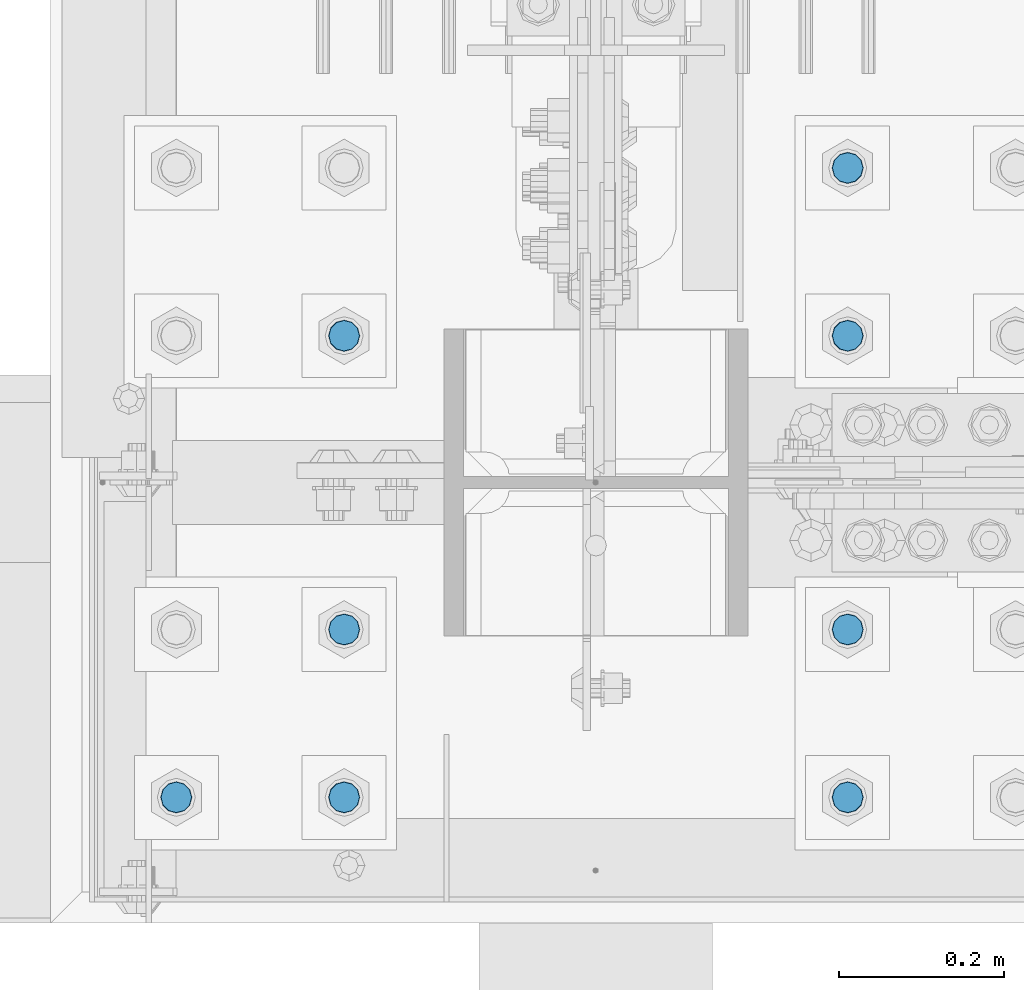
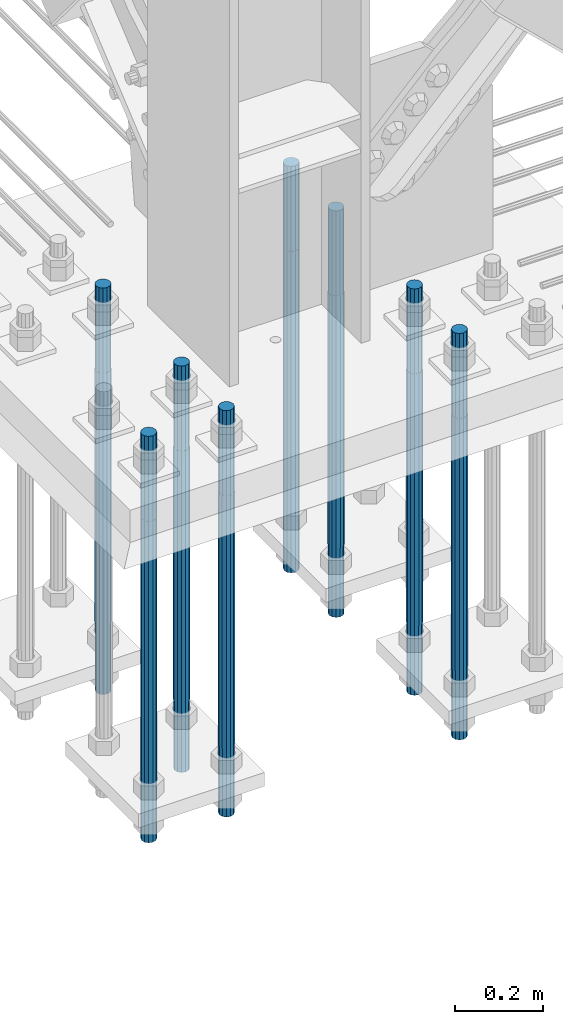
# One storey, part 1288 of 3843: 8 columns, 1 element without a shape of its own.
"""IFC2X3 building model written with IfcOpenShell, lengths in millimetres."""

import ifcopenshell
import ifcopenshell.guid

model = None  # the IFC model being written
_history = None  # IfcOwnerHistory: only IFC2X3 demands one
_inside = {}  # id of a spatial element -> (the spatial element, [elements in it])
_under = {}  # id of a project, library or spatial element -> (it, [spatial elements below it])
_declared = {}  # id of a project -> (the project, [libraries it declares])
_typed = {}  # id of a type object -> (the type object, [elements of that type])
_made_of = {}  # id of a material, layer set ... -> (it, [elements and type objects made of it])


def new_model(schema):
    """Start an empty IFC model of exactly this schema.

    Asked for "IFC4X3", IfcOpenShell would pick the latest addendum, in which some entities
    have other attributes; the version numbers below select the first issue.
    IFC2X3 requires an IfcOwnerHistory on every rooted entity: one is made here for all.
    """
    global model, _history
    if schema == "IFC4X3":
        model = ifcopenshell.file(schema_version=(4, 3, 0, 0))
    else:
        model = ifcopenshell.file(schema=schema)
    _inside.clear()
    _under.clear()
    _declared.clear()
    _typed.clear()
    _made_of.clear()
    _history = None
    if model.schema == "IFC2X3":
        org = make("IfcOrganization", Name="unknown")
        user = make(
            "IfcPersonAndOrganization",
            ThePerson=make("IfcPerson", FamilyName="unknown"),
            TheOrganization=org,
        )
        app = make(
            "IfcApplication",
            ApplicationDeveloper=org,
            Version="unknown",
            ApplicationFullName="unknown",
            ApplicationIdentifier="unknown",
        )
        _history = make(
            "IfcOwnerHistory",
            OwningUser=user,
            OwningApplication=app,
            ChangeAction="ADDED",
            CreationDate=0,
        )
    return model


def make(cls, **values):
    """One entity of the class cls with the attributes given. An attribute that is None is left unset."""
    return model.create_entity(
        cls, **{name: value for name, value in values.items() if value is not None}
    )


def rooted(cls, **values):
    """An entity with a GlobalId (a new one), such as an element, a storey or a relation."""
    return make(cls, GlobalId=ifcopenshell.guid.new(), OwnerHistory=_history, **values)


def si_unit(unit_type, name, prefix=None):
    """IfcSIUnit, for example si_unit("LENGTHUNIT", "METRE", prefix="MILLI")."""
    return make("IfcSIUnit", UnitType=unit_type, Prefix=prefix, Name=name)


def assignment(units):
    """IfcUnitAssignment: the units of a project."""
    return None if units is None else make("IfcUnitAssignment", Units=units)


def point(xyz):
    """IfcCartesianPoint."""
    return None if xyz is None else make("IfcCartesianPoint", Coordinates=xyz)


def direction(xyz):
    """IfcDirection."""
    return None if xyz is None else make("IfcDirection", DirectionRatios=xyz)


def frame(location, z_axis=None, x_axis=None):
    """IfcAxis2Placement3D, a coordinate frame: its origin and axes. An axis left out is left unset."""
    return make(
        "IfcAxis2Placement3D",
        Location=point(location),
        Axis=direction(z_axis),
        RefDirection=direction(x_axis),
    )


def origin_with_axes():
    """The frame at (0, 0, 0) with the z axis (0, 0, 1) and the x axis (1, 0, 0) written out."""
    return frame((0.0, 0.0, 0.0), z_axis=(0.0, 0.0, 1.0), x_axis=(1.0, 0.0, 0.0))


def place(relative_to, where):
    """IfcLocalPlacement: puts the frame where relative to a parent placement (None: the world)."""
    return make(
        "IfcLocalPlacement", PlacementRelTo=relative_to, RelativePlacement=where
    )


def context(
    kind, dimensions, precision=None, world=None, true_north=None, identifier=None
):
    """IfcGeometricRepresentationContext, for example the 3D "Model" context."""
    return make(
        "IfcGeometricRepresentationContext",
        ContextIdentifier=identifier,
        ContextType=kind,
        CoordinateSpaceDimension=dimensions,
        Precision=precision,
        WorldCoordinateSystem=world,
        TrueNorth=true_north,
    )


def subcontext(parent, identifier, kind, view, scale=None):
    """IfcGeometricRepresentationSubContext, for example "Body" below "Model"."""
    return make(
        "IfcGeometricRepresentationSubContext",
        ContextIdentifier=identifier,
        ContextType=kind,
        ParentContext=parent,
        TargetScale=scale,
        TargetView=view,
    )


def project(units=None, contexts=None):
    """IfcProject with its units and contexts."""
    return rooted(
        "IfcProject",
        Name="project",
        RepresentationContexts=contexts,
        UnitsInContext=assignment(units),
    )


def spatial(cls, under=None, at=None, **own):
    """A site, building, storey or space (cls), placed at a placement, below another one or the project."""
    s = rooted(cls, ObjectPlacement=at, **own)
    if under is not None:
        _under.setdefault(under.id(), (under, []))[1].append(s)
    return s


def faces_of(points, faces, orient=None, outer=None):
    """IfcFace entities. A face is a list of loops; a loop is a list of indices into points, from 0.

    orient and outer hold one flag for each loop. By default every Orientation is true, the
    first loop of a face is its IfcFaceOuterBound and the others are IfcFaceBound.
    """
    made = []
    for i, loops in enumerate(faces):
        bounds = []
        for j, loop in enumerate(loops):
            is_outer = j == 0 if outer is None else outer[i][j]
            bounds.append(
                make(
                    "IfcFaceOuterBound" if is_outer else "IfcFaceBound",
                    Bound=make("IfcPolyLoop", Polygon=[points[k] for k in loop]),
                    Orientation=True if orient is None else orient[i][j],
                )
            )
        made.append(make("IfcFace", Bounds=bounds))
    return made


def faceted_brep(points, faces, orient=None, outer=None, voids=None):
    """IfcFacetedBrep: a solid bounded by flat faces; with voids (closed shells), ...WithVoids."""
    shared = [point(p) for p in points]
    hull = make("IfcClosedShell", CfsFaces=faces_of(shared, faces, orient, outer))
    if voids is None:
        return make("IfcFacetedBrep", Outer=hull)
    return make(
        "IfcFacetedBrepWithVoids",
        Outer=hull,
        Voids=[
            make(cls, CfsFaces=faces_of(shared, fs, o, b)) for cls, fs, o, b in voids
        ],
    )


def shape(context_of_items, identifier, shape_type, items):
    """IfcShapeRepresentation: the items that make up one representation, for example the "Body"."""
    return make(
        "IfcShapeRepresentation",
        ContextOfItems=context_of_items,
        RepresentationIdentifier=identifier,
        RepresentationType=shape_type,
        Items=items,
    )


def material(Name=None, Category=None):
    """IfcMaterial."""
    return make("IfcMaterial", Name=Name, Category=Category)


def made_of(thing, what):
    """Note that an element or type object is made of a material, layer set ...; save() writes the relation."""
    if what is not None:
        _made_of.setdefault(what.id(), (what, []))[1].append(thing)
    return thing


def type_object(cls, material=None, **own):
    """A type object (cls), such as IfcWallType, which elements share."""
    return made_of(rooted(cls, **own), material)


def element(
    cls,
    number,
    at=None,
    inside=None,
    cuts=None,
    type_object=None,
    material=None,
    context=None,
    identifier="Body",
    shape_type=None,
    held_by="IfcProductDefinitionShape",
    body=None,
    shapes=None,
    **own,
):
    """One element of the class cls, such as IfcWall. Its Tag is "e" and its number.

    at: its placement. inside: the storey or other place that contains it. cuts: it is an
    opening in that element (IfcRelVoidsElement). A single representation is given by context,
    identifier, shape_type and body (its items); several are given by shapes. held_by: the class
    of the entity that holds the representations. save() writes the other relations.
    """
    e = rooted(cls, Tag="e%d" % number, ObjectPlacement=at, **own)
    if body is not None:
        shapes = [shape(context, identifier, shape_type, body)]
    if shapes is not None:
        e.Representation = make(held_by, Representations=shapes)
    if inside is not None:
        _inside.setdefault(inside.id(), (inside, []))[1].append(e)
    if cuts is not None:
        rooted(
            "IfcRelVoidsElement", RelatingBuildingElement=cuts, RelatedOpeningElement=e
        )
    if type_object is not None:
        _typed.setdefault(type_object.id(), (type_object, []))[1].append(e)
    return made_of(e, material)


def aggregate(whole, parts):
    """IfcRelAggregates: a whole, such as a stair, and the parts it consists of."""
    return rooted("IfcRelAggregates", RelatingObject=whole, RelatedObjects=parts)


def save(model, path):
    """Write the relations noted so far, then the file.

    IfcRelAggregates (storeys below a building ...), IfcRelContainedInSpatialStructure (elements
    in a storey), IfcRelDefinesByType, IfcRelAssociatesMaterial and IfcRelDeclares: one each for
    every whole, place, type object, material and project.
    """
    for whole, parts in _under.values():
        aggregate(whole, parts)
    for where, things in _inside.values():
        rooted(
            "IfcRelContainedInSpatialStructure",
            RelatedElements=things,
            RelatingStructure=where,
        )
    for kind, things in _typed.values():
        rooted("IfcRelDefinesByType", RelatedObjects=things, RelatingType=kind)
    for what, things in _made_of.values():
        rooted("IfcRelAssociatesMaterial", RelatedObjects=things, RelatingMaterial=what)
    for by, libraries in _declared.values():
        rooted("IfcRelDeclares", RelatingContext=by, RelatedDefinitions=libraries)
    model.write(path)


model = new_model("IFC2X3")

# Units and contexts
model_context = context("Model", 3, precision=1e-05, world=origin_with_axes())
body_context = subcontext(model_context, "Body", "Model", "MODEL_VIEW")
ifc_project = project(units=[si_unit("LENGTHUNIT", "METRE", prefix="MILLI"), si_unit("AREAUNIT", "SQUARE_METRE"), si_unit("VOLUMEUNIT", "CUBIC_METRE"), si_unit("MASSUNIT", "GRAM", prefix="KILO"), si_unit("TIMEUNIT", "SECOND"), si_unit("PLANEANGLEUNIT", "RADIAN"), si_unit("SOLIDANGLEUNIT", "STERADIAN"), si_unit("THERMODYNAMICTEMPERATUREUNIT", "DEGREE_CELSIUS"), si_unit("LUMINOUSINTENSITYUNIT", "LUMEN")], contexts=[model_context])

# Site, building, storey
site_placement = place(None, origin_with_axes())
site = spatial("IfcSite", under=ifc_project, at=site_placement, CompositionType="ELEMENT")
building_placement = place(site_placement, origin_with_axes())
building = spatial("IfcBuilding", under=site, at=building_placement, Name="Undefined", CompositionType="ELEMENT")
storey_placement = place(building_placement, origin_with_axes())
storey = spatial("IfcBuildingStorey", under=building, at=storey_placement, Name="Undefined", CompositionType="ELEMENT", Elevation=0.0)

# Assembly, columns
assembly_placement = place(storey_placement, origin_with_axes())
assembly = element("IfcElementAssembly", 1, at=assembly_placement, inside=storey, Name="TEMPLATE", AssemblyPlace="NOTDEFINED", PredefinedType="RIGID_FRAME")
ifc_material = material(Name="Undefined/F1554-GR.55")
column_type = type_object("IfcColumnType", PredefinedType="NOTDEFINED")
column_1_placement = place(assembly_placement, frame((77317.6, 14617.7, 30022.8), z_axis=(1.0, 0.0, 0.0), x_axis=(0.0, 0.0, -1.0)))
column_1 = element("IfcColumn", 2, at=column_1_placement, type_object=column_type, material=ifc_material, Name="ANCHOR_ROD", context=body_context, shape_type="Brep", body=[
    faceted_brep([(-234.950000000001, -16.0214699700155, 9.25), (-234.950000000001, -9.25, 16.0214699700155), (-234.950000000001, 0.0, 18.5), (-234.950000000001, 9.25, 16.0214699700155), (-234.950000000001, 16.0214699700155, 9.25), (-234.950000000001, 18.5, 0.0), (-234.950000000001, 16.0214699700155, -9.25), (-234.950000000001, 9.25, -16.0214699700155), (-234.950000000001, 0.0, -18.5), (-234.950000000001, -9.25, -16.0214699700155), (-234.950000000001, -16.0214699700155, -9.25), (-234.950000000001, -18.5, 0.0), (0.0, 18.5, 0.0), (0.0, 16.0214699700118, -9.25), (0.0, 9.25, -16.0214699700155), (0.0, 0.0, -18.5), (0.0, -9.25, -16.0214699700155), (0.0, -16.0214699700118, -9.25), (0.0, -18.5, 0.0), (0.0, -16.0214699700118, 9.25), (0.0, -9.25, 16.0214699700155), (0.0, 0.0, 18.5), (0.0, 9.25, 16.0214699700155), (0.0, 16.0214699700118, 9.25), (0.0, -16.4977839420972, 9.52500000000146), (0.0, -9.52500000000146, 16.4977839420972), (0.0, 0.0, 19.0499989999989), (0.0, 9.52500000000146, 16.4977839420972), (0.0, 16.4977839420972, 9.52500000000146), (0.0, 19.0500000000029, 0.0), (0.0, 16.4977839420972, -9.52500000000146), (0.0, 9.52500000000146, -16.4977839420972), (0.0, 0.0, -19.0499989999989), (0.0, -9.52500000000146, -16.4977839420972), (0.0, -16.4977839420972, -9.52500000000146), (0.0, -19.0500000000029, 0.0), (698.5, -19.0499999999993, 0.0), (698.5, -16.4977839420935, 9.52499999999418), (698.5, -9.52500000000146, 16.4977839420899), (698.5, 0.0, 19.0500000000029), (698.5, 9.52500000000146, 16.4977839420899), (698.5, 16.4977839420935, 9.52499999999418), (698.5, 19.0499999999993, 0.0), (698.5, 16.4977839420935, -9.52499999999418), (698.5, 9.52500000000146, -16.4977839420899), (698.5, 0.0, -19.0500000000029), (698.5, -9.52500000000146, -16.4977839420899), (698.5, -16.4977839420935, -9.52499999999418), (698.5, -9.25, 16.0214699700155), (698.5, 0.0, 18.5), (698.5, 9.25, 16.0214699700155), (698.5, 16.0214699700118, 9.25), (698.5, 18.5, 0.0), (698.5, 16.0214699700118, -9.25), (698.5, 9.25, -16.0214699700155), (698.5, 0.0, -18.5), (698.5, -9.25, -16.0214699700155), (698.5, -16.0214699700118, -9.25), (698.5, -18.5, 0.0), (698.5, -16.0214699700118, 9.25), (889.0, -9.25, -16.0214699700155), (889.0, 0.0, -18.5), (889.0, 9.25, -16.0214699700155), (889.0, 16.0214699700118, -9.25), (889.0, 18.5, 0.0), (889.0, 16.0214699700118, 9.25), (889.0, 9.25, 16.0214699700155), (889.0, 0.0, 18.5), (889.0, -9.25, 16.0214699700155), (889.0, -16.0214699700118, 9.25), (889.0, -18.5, 0.0), (889.0, -16.0214699700118, -9.25)], [[[0, 1, 2, 3, 4, 5, 6, 7, 8, 9, 10, 11]], [[6, 5, 12, 13]], [[7, 6, 13, 14]], [[8, 7, 14, 15]], [[9, 8, 15, 16]], [[10, 9, 16, 17]], [[11, 10, 17, 18]], [[0, 11, 18, 19]], [[1, 0, 19, 20]], [[2, 1, 20, 21]], [[3, 2, 21, 22]], [[4, 3, 22, 23]], [[5, 4, 23, 12]], [[24, 25, 26, 27, 28, 29, 30, 31, 32, 33, 34, 35], [22, 21, 20, 19, 18, 17, 16, 15, 14, 13, 12, 23]], [[24, 35, 36, 37]], [[25, 24, 37, 38]], [[26, 25, 38, 39]], [[27, 26, 39, 40]], [[28, 27, 40, 41]], [[29, 28, 41, 42]], [[30, 29, 42, 43]], [[31, 30, 43, 44]], [[32, 31, 44, 45]], [[33, 32, 45, 46]], [[34, 33, 46, 47]], [[35, 34, 47, 36]], [[46, 45, 44, 43, 42, 41, 40, 39, 38, 37, 36, 47], [48, 49, 50, 51, 52, 53, 54, 55, 56, 57, 58, 59]], [[60, 61, 62, 63, 64, 65, 66, 67, 68, 69, 70, 71]], [[68, 67, 49, 48]], [[69, 68, 48, 59]], [[70, 69, 59, 58]], [[71, 70, 58, 57]], [[60, 71, 57, 56]], [[61, 60, 56, 55]], [[62, 61, 55, 54]], [[63, 62, 54, 53]], [[64, 63, 53, 52]], [[65, 64, 52, 51]], [[66, 65, 51, 50]], [[67, 66, 50, 49]]]),
])
column_2_placement = place(assembly_placement, frame((77317.6, 14820.9, 30022.8), z_axis=(1.0, 0.0, 0.0), x_axis=(0.0, 0.0, -1.0)))
column_2 = element("IfcColumn", 3, at=column_2_placement, type_object=column_type, material=ifc_material, Name="ANCHOR_ROD", context=body_context, shape_type="Brep", body=[
    faceted_brep([(-234.950000000001, -16.0214699700155, 9.25), (-234.950000000001, -9.25, 16.0214699700155), (-234.950000000001, 0.0, 18.5), (-234.950000000001, 9.25, 16.0214699700155), (-234.950000000001, 16.0214699700155, 9.25), (-234.950000000001, 18.5, 0.0), (-234.950000000001, 16.0214699700155, -9.25), (-234.950000000001, 9.25, -16.0214699700155), (-234.950000000001, 0.0, -18.5), (-234.950000000001, -9.25, -16.0214699700155), (-234.950000000001, -16.0214699700155, -9.25), (-234.950000000001, -18.5, 0.0), (0.0, 18.5, 0.0), (0.0, 16.0214699700118, -9.25), (0.0, 9.25, -16.0214699700155), (0.0, 0.0, -18.5), (0.0, -9.25, -16.0214699700155), (0.0, -16.0214699700118, -9.25), (0.0, -18.5, 0.0), (0.0, -16.0214699700118, 9.25), (0.0, -9.25, 16.0214699700155), (0.0, 0.0, 18.5), (0.0, 9.25, 16.0214699700155), (0.0, 16.0214699700118, 9.25), (0.0, -16.4977839420972, 9.52500000000146), (0.0, -9.52500000000146, 16.4977839420972), (0.0, 0.0, 19.0499989999989), (0.0, 9.52500000000146, 16.4977839420972), (0.0, 16.4977839420972, 9.52500000000146), (0.0, 19.0500000000029, 0.0), (0.0, 16.4977839420972, -9.52500000000146), (0.0, 9.52500000000146, -16.4977839420972), (0.0, 0.0, -19.0499989999989), (0.0, -9.52500000000146, -16.4977839420972), (0.0, -16.4977839420972, -9.52500000000146), (0.0, -19.0500000000029, 0.0), (698.5, -19.0499999999993, 0.0), (698.5, -16.4977839420935, 9.52499999999418), (698.5, -9.52500000000146, 16.4977839420899), (698.5, 0.0, 19.0500000000029), (698.5, 9.52500000000146, 16.4977839420899), (698.5, 16.4977839420935, 9.52499999999418), (698.5, 19.0499999999993, 0.0), (698.5, 16.4977839420935, -9.52499999999418), (698.5, 9.52500000000146, -16.4977839420899), (698.5, 0.0, -19.0500000000029), (698.5, -9.52500000000146, -16.4977839420899), (698.5, -16.4977839420935, -9.52499999999418), (698.5, -9.25, 16.0214699700155), (698.5, 0.0, 18.5), (698.5, 9.25, 16.0214699700155), (698.5, 16.0214699700118, 9.25), (698.5, 18.5, 0.0), (698.5, 16.0214699700118, -9.25), (698.5, 9.25, -16.0214699700155), (698.5, 0.0, -18.5), (698.5, -9.25, -16.0214699700155), (698.5, -16.0214699700118, -9.25), (698.5, -18.5, 0.0), (698.5, -16.0214699700118, 9.25), (889.0, -9.25, -16.0214699700155), (889.0, 0.0, -18.5), (889.0, 9.25, -16.0214699700155), (889.0, 16.0214699700118, -9.25), (889.0, 18.5, 0.0), (889.0, 16.0214699700118, 9.25), (889.0, 9.25, 16.0214699700155), (889.0, 0.0, 18.5), (889.0, -9.25, 16.0214699700155), (889.0, -16.0214699700118, 9.25), (889.0, -18.5, 0.0), (889.0, -16.0214699700118, -9.25)], [[[0, 1, 2, 3, 4, 5, 6, 7, 8, 9, 10, 11]], [[6, 5, 12, 13]], [[7, 6, 13, 14]], [[8, 7, 14, 15]], [[9, 8, 15, 16]], [[10, 9, 16, 17]], [[11, 10, 17, 18]], [[0, 11, 18, 19]], [[1, 0, 19, 20]], [[2, 1, 20, 21]], [[3, 2, 21, 22]], [[4, 3, 22, 23]], [[5, 4, 23, 12]], [[24, 25, 26, 27, 28, 29, 30, 31, 32, 33, 34, 35], [22, 21, 20, 19, 18, 17, 16, 15, 14, 13, 12, 23]], [[24, 35, 36, 37]], [[25, 24, 37, 38]], [[26, 25, 38, 39]], [[27, 26, 39, 40]], [[28, 27, 40, 41]], [[29, 28, 41, 42]], [[30, 29, 42, 43]], [[31, 30, 43, 44]], [[32, 31, 44, 45]], [[33, 32, 45, 46]], [[34, 33, 46, 47]], [[35, 34, 47, 36]], [[46, 45, 44, 43, 42, 41, 40, 39, 38, 37, 36, 47], [48, 49, 50, 51, 52, 53, 54, 55, 56, 57, 58, 59]], [[60, 61, 62, 63, 64, 65, 66, 67, 68, 69, 70, 71]], [[68, 67, 49, 48]], [[69, 68, 48, 59]], [[70, 69, 59, 58]], [[71, 70, 58, 57]], [[60, 71, 57, 56]], [[61, 60, 56, 55]], [[62, 61, 55, 54]], [[63, 62, 54, 53]], [[64, 63, 53, 52]], [[65, 64, 52, 51]], [[66, 65, 51, 50]], [[67, 66, 50, 49]]]),
])
column_3_placement = place(assembly_placement, frame((77317.6, 15176.5, 30022.8), z_axis=(-1.0, 0.0, 0.0), x_axis=(0.0, 0.0, -1.0)))
column_3 = element("IfcColumn", 4, at=column_3_placement, type_object=column_type, material=ifc_material, Name="ANCHOR_ROD", context=body_context, shape_type="Brep", body=[
    faceted_brep([(-234.950000000001, -16.0214699700155, 9.25), (-234.950000000001, -9.25, 16.0214699700155), (-234.950000000001, 0.0, 18.5), (-234.950000000001, 9.25, 16.0214699700155), (-234.950000000001, 16.0214699700155, 9.25), (-234.950000000001, 18.5, 0.0), (-234.950000000001, 16.0214699700155, -9.25), (-234.950000000001, 9.25, -16.0214699700155), (-234.950000000001, 0.0, -18.5), (-234.950000000001, -9.25, -16.0214699700155), (-234.950000000001, -16.0214699700155, -9.25), (-234.950000000001, -18.5, 0.0), (0.0, 18.5, 0.0), (0.0, 16.0214699700118, -9.25), (0.0, 9.25, -16.0214699700155), (0.0, 0.0, -18.5), (0.0, -9.25, -16.0214699700155), (0.0, -16.0214699700118, -9.25), (0.0, -18.5, 0.0), (0.0, -16.0214699700118, 9.25), (0.0, -9.25, 16.0214699700155), (0.0, 0.0, 18.5), (0.0, 9.25, 16.0214699700155), (0.0, 16.0214699700118, 9.25), (0.0, -16.4977839420972, 9.52500000000146), (0.0, -9.52500000000146, 16.4977839420972), (0.0, 0.0, 19.0499989999989), (0.0, 9.52500000000146, 16.4977839420972), (0.0, 16.4977839420972, 9.52500000000146), (0.0, 19.0500000000029, 0.0), (0.0, 16.4977839420972, -9.52500000000146), (0.0, 9.52500000000146, -16.4977839420972), (0.0, 0.0, -19.0499989999989), (0.0, -9.52500000000146, -16.4977839420972), (0.0, -16.4977839420972, -9.52500000000146), (0.0, -19.0500000000029, 0.0), (698.5, -19.0499999999993, 0.0), (698.5, -16.4977839420935, 9.52499999999418), (698.5, -9.52500000000146, 16.4977839420899), (698.5, 0.0, 19.0500000000029), (698.5, 9.52500000000146, 16.4977839420899), (698.5, 16.4977839420935, 9.52499999999418), (698.5, 19.0499999999993, 0.0), (698.5, 16.4977839420935, -9.52499999999418), (698.5, 9.52500000000146, -16.4977839420899), (698.5, 0.0, -19.0500000000029), (698.5, -9.52500000000146, -16.4977839420899), (698.5, -16.4977839420935, -9.52499999999418), (698.5, -9.25, 16.0214699700155), (698.5, 0.0, 18.5), (698.5, 9.25, 16.0214699700155), (698.5, 16.0214699700118, 9.25), (698.5, 18.5, 0.0), (698.5, 16.0214699700118, -9.25), (698.5, 9.25, -16.0214699700155), (698.5, 0.0, -18.5), (698.5, -9.25, -16.0214699700155), (698.5, -16.0214699700118, -9.25), (698.5, -18.5, 0.0), (698.5, -16.0214699700118, 9.25), (889.0, -9.25, -16.0214699700155), (889.0, 0.0, -18.5), (889.0, 9.25, -16.0214699700155), (889.0, 16.0214699700118, -9.25), (889.0, 18.5, 0.0), (889.0, 16.0214699700118, 9.25), (889.0, 9.25, 16.0214699700155), (889.0, 0.0, 18.5), (889.0, -9.25, 16.0214699700155), (889.0, -16.0214699700118, 9.25), (889.0, -18.5, 0.0), (889.0, -16.0214699700118, -9.25)], [[[0, 1, 2, 3, 4, 5, 6, 7, 8, 9, 10, 11]], [[6, 5, 12, 13]], [[7, 6, 13, 14]], [[8, 7, 14, 15]], [[9, 8, 15, 16]], [[10, 9, 16, 17]], [[11, 10, 17, 18]], [[0, 11, 18, 19]], [[1, 0, 19, 20]], [[2, 1, 20, 21]], [[3, 2, 21, 22]], [[4, 3, 22, 23]], [[5, 4, 23, 12]], [[24, 25, 26, 27, 28, 29, 30, 31, 32, 33, 34, 35], [22, 21, 20, 19, 18, 17, 16, 15, 14, 13, 12, 23]], [[24, 35, 36, 37]], [[25, 24, 37, 38]], [[26, 25, 38, 39]], [[27, 26, 39, 40]], [[28, 27, 40, 41]], [[29, 28, 41, 42]], [[30, 29, 42, 43]], [[31, 30, 43, 44]], [[32, 31, 44, 45]], [[33, 32, 45, 46]], [[34, 33, 46, 47]], [[35, 34, 47, 36]], [[46, 45, 44, 43, 42, 41, 40, 39, 38, 37, 36, 47], [48, 49, 50, 51, 52, 53, 54, 55, 56, 57, 58, 59]], [[60, 61, 62, 63, 64, 65, 66, 67, 68, 69, 70, 71]], [[68, 67, 49, 48]], [[69, 68, 48, 59]], [[70, 69, 59, 58]], [[71, 70, 58, 57]], [[60, 71, 57, 56]], [[61, 60, 56, 55]], [[62, 61, 55, 54]], [[63, 62, 54, 53]], [[64, 63, 53, 52]], [[65, 64, 52, 51]], [[66, 65, 51, 50]], [[67, 66, 50, 49]]]),
])
column_4_placement = place(assembly_placement, frame((77317.6, 15379.7, 30022.8), z_axis=(-1.0, 0.0, 0.0), x_axis=(0.0, 0.0, -1.0)))
column_4 = element("IfcColumn", 5, at=column_4_placement, type_object=column_type, material=ifc_material, Name="ANCHOR_ROD", context=body_context, shape_type="Brep", body=[
    faceted_brep([(-234.950000000001, -16.0214699700155, 9.25), (-234.950000000001, -9.25, 16.0214699700155), (-234.950000000001, 0.0, 18.5), (-234.950000000001, 9.25, 16.0214699700155), (-234.950000000001, 16.0214699700155, 9.25), (-234.950000000001, 18.5, 0.0), (-234.950000000001, 16.0214699700155, -9.25), (-234.950000000001, 9.25, -16.0214699700155), (-234.950000000001, 0.0, -18.5), (-234.950000000001, -9.25, -16.0214699700155), (-234.950000000001, -16.0214699700155, -9.25), (-234.950000000001, -18.5, 0.0), (0.0, 18.5, 0.0), (0.0, 16.0214699700118, -9.25), (0.0, 9.25, -16.0214699700155), (0.0, 0.0, -18.5), (0.0, -9.25, -16.0214699700155), (0.0, -16.0214699700118, -9.25), (0.0, -18.5, 0.0), (0.0, -16.0214699700118, 9.25), (0.0, -9.25, 16.0214699700155), (0.0, 0.0, 18.5), (0.0, 9.25, 16.0214699700155), (0.0, 16.0214699700118, 9.25), (0.0, -16.4977839420972, 9.52500000000146), (0.0, -9.52500000000146, 16.4977839420972), (0.0, 0.0, 19.0499989999989), (0.0, 9.52500000000146, 16.4977839420972), (0.0, 16.4977839420972, 9.52500000000146), (0.0, 19.0500000000029, 0.0), (0.0, 16.4977839420972, -9.52500000000146), (0.0, 9.52500000000146, -16.4977839420972), (0.0, 0.0, -19.0499989999989), (0.0, -9.52500000000146, -16.4977839420972), (0.0, -16.4977839420972, -9.52500000000146), (0.0, -19.0500000000029, 0.0), (698.5, -19.0499999999993, 0.0), (698.5, -16.4977839420935, 9.52499999999418), (698.5, -9.52500000000146, 16.4977839420899), (698.5, 0.0, 19.0500000000029), (698.5, 9.52500000000146, 16.4977839420899), (698.5, 16.4977839420935, 9.52499999999418), (698.5, 19.0499999999993, 0.0), (698.5, 16.4977839420935, -9.52499999999418), (698.5, 9.52500000000146, -16.4977839420899), (698.5, 0.0, -19.0500000000029), (698.5, -9.52500000000146, -16.4977839420899), (698.5, -16.4977839420935, -9.52499999999418), (698.5, -9.25, 16.0214699700155), (698.5, 0.0, 18.5), (698.5, 9.25, 16.0214699700155), (698.5, 16.0214699700118, 9.25), (698.5, 18.5, 0.0), (698.5, 16.0214699700118, -9.25), (698.5, 9.25, -16.0214699700155), (698.5, 0.0, -18.5), (698.5, -9.25, -16.0214699700155), (698.5, -16.0214699700118, -9.25), (698.5, -18.5, 0.0), (698.5, -16.0214699700118, 9.25), (889.0, -9.25, -16.0214699700155), (889.0, 0.0, -18.5), (889.0, 9.25, -16.0214699700155), (889.0, 16.0214699700118, -9.25), (889.0, 18.5, 0.0), (889.0, 16.0214699700118, 9.25), (889.0, 9.25, 16.0214699700155), (889.0, 0.0, 18.5), (889.0, -9.25, 16.0214699700155), (889.0, -16.0214699700118, 9.25), (889.0, -18.5, 0.0), (889.0, -16.0214699700118, -9.25)], [[[0, 1, 2, 3, 4, 5, 6, 7, 8, 9, 10, 11]], [[6, 5, 12, 13]], [[7, 6, 13, 14]], [[8, 7, 14, 15]], [[9, 8, 15, 16]], [[10, 9, 16, 17]], [[11, 10, 17, 18]], [[0, 11, 18, 19]], [[1, 0, 19, 20]], [[2, 1, 20, 21]], [[3, 2, 21, 22]], [[4, 3, 22, 23]], [[5, 4, 23, 12]], [[24, 25, 26, 27, 28, 29, 30, 31, 32, 33, 34, 35], [22, 21, 20, 19, 18, 17, 16, 15, 14, 13, 12, 23]], [[24, 35, 36, 37]], [[25, 24, 37, 38]], [[26, 25, 38, 39]], [[27, 26, 39, 40]], [[28, 27, 40, 41]], [[29, 28, 41, 42]], [[30, 29, 42, 43]], [[31, 30, 43, 44]], [[32, 31, 44, 45]], [[33, 32, 45, 46]], [[34, 33, 46, 47]], [[35, 34, 47, 36]], [[46, 45, 44, 43, 42, 41, 40, 39, 38, 37, 36, 47], [48, 49, 50, 51, 52, 53, 54, 55, 56, 57, 58, 59]], [[60, 61, 62, 63, 64, 65, 66, 67, 68, 69, 70, 71]], [[68, 67, 49, 48]], [[69, 68, 48, 59]], [[70, 69, 59, 58]], [[71, 70, 58, 57]], [[60, 71, 57, 56]], [[61, 60, 56, 55]], [[62, 61, 55, 54]], [[63, 62, 54, 53]], [[64, 63, 53, 52]], [[65, 64, 52, 51]], [[66, 65, 51, 50]], [[67, 66, 50, 49]]]),
])
column_5_placement = place(assembly_placement, frame((76708.0, 14617.7, 30022.8), z_axis=(1.0, 0.0, 0.0), x_axis=(0.0, 0.0, -1.0)))
column_5 = element("IfcColumn", 6, at=column_5_placement, type_object=column_type, material=ifc_material, Name="ANCHOR_ROD", context=body_context, shape_type="Brep", body=[
    faceted_brep([(-234.950000000001, -16.0214699700155, 9.25), (-234.950000000001, -9.25, 16.0214699700155), (-234.950000000001, 0.0, 18.5), (-234.950000000001, 9.25, 16.0214699700155), (-234.950000000001, 16.0214699700155, 9.25), (-234.950000000001, 18.5, 0.0), (-234.950000000001, 16.0214699700155, -9.25), (-234.950000000001, 9.25, -16.0214699700155), (-234.950000000001, 0.0, -18.5), (-234.950000000001, -9.25, -16.0214699700155), (-234.950000000001, -16.0214699700155, -9.25), (-234.950000000001, -18.5, 0.0), (0.0, 18.5, 0.0), (0.0, 16.0214699700118, -9.25), (0.0, 9.25, -16.0214699700155), (0.0, 0.0, -18.5), (0.0, -9.25, -16.0214699700155), (0.0, -16.0214699700118, -9.25), (0.0, -18.5, 0.0), (0.0, -16.0214699700118, 9.25), (0.0, -9.25, 16.0214699700155), (0.0, 0.0, 18.5), (0.0, 9.25, 16.0214699700155), (0.0, 16.0214699700118, 9.25), (0.0, -16.4977839420972, 9.52500000000146), (0.0, -9.52500000000146, 16.4977839420972), (0.0, 0.0, 19.0499989999989), (0.0, 9.52500000000146, 16.4977839420972), (0.0, 16.4977839420972, 9.52500000000146), (0.0, 19.0500000000029, 0.0), (0.0, 16.4977839420972, -9.52500000000146), (0.0, 9.52500000000146, -16.4977839420972), (0.0, 0.0, -19.0499989999989), (0.0, -9.52500000000146, -16.4977839420972), (0.0, -16.4977839420972, -9.52500000000146), (0.0, -19.0500000000029, 0.0), (698.5, -19.0499999999993, 0.0), (698.5, -16.4977839420935, 9.52499999999418), (698.5, -9.52500000000146, 16.4977839420899), (698.5, 0.0, 19.0500000000029), (698.5, 9.52500000000146, 16.4977839420899), (698.5, 16.4977839420935, 9.52499999999418), (698.5, 19.0499999999993, 0.0), (698.5, 16.4977839420935, -9.52499999999418), (698.5, 9.52500000000146, -16.4977839420899), (698.5, 0.0, -19.0500000000029), (698.5, -9.52500000000146, -16.4977839420899), (698.5, -16.4977839420935, -9.52499999999418), (698.5, -9.25, 16.0214699700155), (698.5, 0.0, 18.5), (698.5, 9.25, 16.0214699700155), (698.5, 16.0214699700118, 9.25), (698.5, 18.5, 0.0), (698.5, 16.0214699700118, -9.25), (698.5, 9.25, -16.0214699700155), (698.5, 0.0, -18.5), (698.5, -9.25, -16.0214699700155), (698.5, -16.0214699700118, -9.25), (698.5, -18.5, 0.0), (698.5, -16.0214699700118, 9.25), (889.0, -9.25, -16.0214699700155), (889.0, 0.0, -18.5), (889.0, 9.25, -16.0214699700155), (889.0, 16.0214699700118, -9.25), (889.0, 18.5, 0.0), (889.0, 16.0214699700118, 9.25), (889.0, 9.25, 16.0214699700155), (889.0, 0.0, 18.5), (889.0, -9.25, 16.0214699700155), (889.0, -16.0214699700118, 9.25), (889.0, -18.5, 0.0), (889.0, -16.0214699700118, -9.25)], [[[0, 1, 2, 3, 4, 5, 6, 7, 8, 9, 10, 11]], [[6, 5, 12, 13]], [[7, 6, 13, 14]], [[8, 7, 14, 15]], [[9, 8, 15, 16]], [[10, 9, 16, 17]], [[11, 10, 17, 18]], [[0, 11, 18, 19]], [[1, 0, 19, 20]], [[2, 1, 20, 21]], [[3, 2, 21, 22]], [[4, 3, 22, 23]], [[5, 4, 23, 12]], [[24, 25, 26, 27, 28, 29, 30, 31, 32, 33, 34, 35], [22, 21, 20, 19, 18, 17, 16, 15, 14, 13, 12, 23]], [[24, 35, 36, 37]], [[25, 24, 37, 38]], [[26, 25, 38, 39]], [[27, 26, 39, 40]], [[28, 27, 40, 41]], [[29, 28, 41, 42]], [[30, 29, 42, 43]], [[31, 30, 43, 44]], [[32, 31, 44, 45]], [[33, 32, 45, 46]], [[34, 33, 46, 47]], [[35, 34, 47, 36]], [[46, 45, 44, 43, 42, 41, 40, 39, 38, 37, 36, 47], [48, 49, 50, 51, 52, 53, 54, 55, 56, 57, 58, 59]], [[60, 61, 62, 63, 64, 65, 66, 67, 68, 69, 70, 71]], [[68, 67, 49, 48]], [[69, 68, 48, 59]], [[70, 69, 59, 58]], [[71, 70, 58, 57]], [[60, 71, 57, 56]], [[61, 60, 56, 55]], [[62, 61, 55, 54]], [[63, 62, 54, 53]], [[64, 63, 53, 52]], [[65, 64, 52, 51]], [[66, 65, 51, 50]], [[67, 66, 50, 49]]]),
])
column_6_placement = place(assembly_placement, frame((76708.0, 14820.9, 30022.8), z_axis=(1.0, 0.0, 0.0), x_axis=(0.0, 0.0, -1.0)))
column_6 = element("IfcColumn", 7, at=column_6_placement, type_object=column_type, material=ifc_material, Name="ANCHOR_ROD", context=body_context, shape_type="Brep", body=[
    faceted_brep([(-234.950000000001, -16.0214699700155, 9.25), (-234.950000000001, -9.25, 16.0214699700155), (-234.950000000001, 0.0, 18.5), (-234.950000000001, 9.25, 16.0214699700155), (-234.950000000001, 16.0214699700155, 9.25), (-234.950000000001, 18.5, 0.0), (-234.950000000001, 16.0214699700155, -9.25), (-234.950000000001, 9.25, -16.0214699700155), (-234.950000000001, 0.0, -18.5), (-234.950000000001, -9.25, -16.0214699700155), (-234.950000000001, -16.0214699700155, -9.25), (-234.950000000001, -18.5, 0.0), (0.0, 18.5, 0.0), (0.0, 16.0214699700118, -9.25), (0.0, 9.25, -16.0214699700155), (0.0, 0.0, -18.5), (0.0, -9.25, -16.0214699700155), (0.0, -16.0214699700118, -9.25), (0.0, -18.5, 0.0), (0.0, -16.0214699700118, 9.25), (0.0, -9.25, 16.0214699700155), (0.0, 0.0, 18.5), (0.0, 9.25, 16.0214699700155), (0.0, 16.0214699700118, 9.25), (0.0, -16.4977839420972, 9.52500000000146), (0.0, -9.52500000000146, 16.4977839420972), (0.0, 0.0, 19.0499989999989), (0.0, 9.52500000000146, 16.4977839420972), (0.0, 16.4977839420972, 9.52500000000146), (0.0, 19.0500000000029, 0.0), (0.0, 16.4977839420972, -9.52500000000146), (0.0, 9.52500000000146, -16.4977839420972), (0.0, 0.0, -19.0499989999989), (0.0, -9.52500000000146, -16.4977839420972), (0.0, -16.4977839420972, -9.52500000000146), (0.0, -19.0500000000029, 0.0), (698.5, -19.0499999999993, 0.0), (698.5, -16.4977839420935, 9.52499999999418), (698.5, -9.52500000000146, 16.4977839420899), (698.5, 0.0, 19.0500000000029), (698.5, 9.52500000000146, 16.4977839420899), (698.5, 16.4977839420935, 9.52499999999418), (698.5, 19.0499999999993, 0.0), (698.5, 16.4977839420935, -9.52499999999418), (698.5, 9.52500000000146, -16.4977839420899), (698.5, 0.0, -19.0500000000029), (698.5, -9.52500000000146, -16.4977839420899), (698.5, -16.4977839420935, -9.52499999999418), (698.5, -9.25, 16.0214699700155), (698.5, 0.0, 18.5), (698.5, 9.25, 16.0214699700155), (698.5, 16.0214699700118, 9.25), (698.5, 18.5, 0.0), (698.5, 16.0214699700118, -9.25), (698.5, 9.25, -16.0214699700155), (698.5, 0.0, -18.5), (698.5, -9.25, -16.0214699700155), (698.5, -16.0214699700118, -9.25), (698.5, -18.5, 0.0), (698.5, -16.0214699700118, 9.25), (889.0, -9.25, -16.0214699700155), (889.0, 0.0, -18.5), (889.0, 9.25, -16.0214699700155), (889.0, 16.0214699700118, -9.25), (889.0, 18.5, 0.0), (889.0, 16.0214699700118, 9.25), (889.0, 9.25, 16.0214699700155), (889.0, 0.0, 18.5), (889.0, -9.25, 16.0214699700155), (889.0, -16.0214699700118, 9.25), (889.0, -18.5, 0.0), (889.0, -16.0214699700118, -9.25)], [[[0, 1, 2, 3, 4, 5, 6, 7, 8, 9, 10, 11]], [[6, 5, 12, 13]], [[7, 6, 13, 14]], [[8, 7, 14, 15]], [[9, 8, 15, 16]], [[10, 9, 16, 17]], [[11, 10, 17, 18]], [[0, 11, 18, 19]], [[1, 0, 19, 20]], [[2, 1, 20, 21]], [[3, 2, 21, 22]], [[4, 3, 22, 23]], [[5, 4, 23, 12]], [[24, 25, 26, 27, 28, 29, 30, 31, 32, 33, 34, 35], [22, 21, 20, 19, 18, 17, 16, 15, 14, 13, 12, 23]], [[24, 35, 36, 37]], [[25, 24, 37, 38]], [[26, 25, 38, 39]], [[27, 26, 39, 40]], [[28, 27, 40, 41]], [[29, 28, 41, 42]], [[30, 29, 42, 43]], [[31, 30, 43, 44]], [[32, 31, 44, 45]], [[33, 32, 45, 46]], [[34, 33, 46, 47]], [[35, 34, 47, 36]], [[46, 45, 44, 43, 42, 41, 40, 39, 38, 37, 36, 47], [48, 49, 50, 51, 52, 53, 54, 55, 56, 57, 58, 59]], [[60, 61, 62, 63, 64, 65, 66, 67, 68, 69, 70, 71]], [[68, 67, 49, 48]], [[69, 68, 48, 59]], [[70, 69, 59, 58]], [[71, 70, 58, 57]], [[60, 71, 57, 56]], [[61, 60, 56, 55]], [[62, 61, 55, 54]], [[63, 62, 54, 53]], [[64, 63, 53, 52]], [[65, 64, 52, 51]], [[66, 65, 51, 50]], [[67, 66, 50, 49]]]),
])
column_7_placement = place(assembly_placement, frame((76708.0, 15176.5, 30022.8), z_axis=(-1.0, 0.0, 0.0), x_axis=(0.0, 0.0, -1.0)))
column_7 = element("IfcColumn", 8, at=column_7_placement, type_object=column_type, material=ifc_material, Name="ANCHOR_ROD", context=body_context, shape_type="Brep", body=[
    faceted_brep([(-234.950000000001, -16.0214699700155, 9.25), (-234.950000000001, -9.25, 16.0214699700155), (-234.950000000001, 0.0, 18.5), (-234.950000000001, 9.25, 16.0214699700155), (-234.950000000001, 16.0214699700155, 9.25), (-234.950000000001, 18.5, 0.0), (-234.950000000001, 16.0214699700155, -9.25), (-234.950000000001, 9.25, -16.0214699700155), (-234.950000000001, 0.0, -18.5), (-234.950000000001, -9.25, -16.0214699700155), (-234.950000000001, -16.0214699700155, -9.25), (-234.950000000001, -18.5, 0.0), (0.0, 18.5, 0.0), (0.0, 16.0214699700118, -9.25), (0.0, 9.25, -16.0214699700155), (0.0, 0.0, -18.5), (0.0, -9.25, -16.0214699700155), (0.0, -16.0214699700118, -9.25), (0.0, -18.5, 0.0), (0.0, -16.0214699700118, 9.25), (0.0, -9.25, 16.0214699700155), (0.0, 0.0, 18.5), (0.0, 9.25, 16.0214699700155), (0.0, 16.0214699700118, 9.25), (0.0, -16.4977839420972, 9.52500000000146), (0.0, -9.52500000000146, 16.4977839420972), (0.0, 0.0, 19.0499989999989), (0.0, 9.52500000000146, 16.4977839420972), (0.0, 16.4977839420972, 9.52500000000146), (0.0, 19.0500000000029, 0.0), (0.0, 16.4977839420972, -9.52500000000146), (0.0, 9.52500000000146, -16.4977839420972), (0.0, 0.0, -19.0499989999989), (0.0, -9.52500000000146, -16.4977839420972), (0.0, -16.4977839420972, -9.52500000000146), (0.0, -19.0500000000029, 0.0), (698.5, -19.0499999999993, 0.0), (698.5, -16.4977839420935, 9.52499999999418), (698.5, -9.52500000000146, 16.4977839420899), (698.5, 0.0, 19.0500000000029), (698.5, 9.52500000000146, 16.4977839420899), (698.5, 16.4977839420935, 9.52499999999418), (698.5, 19.0499999999993, 0.0), (698.5, 16.4977839420935, -9.52499999999418), (698.5, 9.52500000000146, -16.4977839420899), (698.5, 0.0, -19.0500000000029), (698.5, -9.52500000000146, -16.4977839420899), (698.5, -16.4977839420935, -9.52499999999418), (698.5, -9.25, 16.0214699700155), (698.5, 0.0, 18.5), (698.5, 9.25, 16.0214699700155), (698.5, 16.0214699700118, 9.25), (698.5, 18.5, 0.0), (698.5, 16.0214699700118, -9.25), (698.5, 9.25, -16.0214699700155), (698.5, 0.0, -18.5), (698.5, -9.25, -16.0214699700155), (698.5, -16.0214699700118, -9.25), (698.5, -18.5, 0.0), (698.5, -16.0214699700118, 9.25), (889.0, -9.25, -16.0214699700155), (889.0, 0.0, -18.5), (889.0, 9.25, -16.0214699700155), (889.0, 16.0214699700118, -9.25), (889.0, 18.5, 0.0), (889.0, 16.0214699700118, 9.25), (889.0, 9.25, 16.0214699700155), (889.0, 0.0, 18.5), (889.0, -9.25, 16.0214699700155), (889.0, -16.0214699700118, 9.25), (889.0, -18.5, 0.0), (889.0, -16.0214699700118, -9.25)], [[[0, 1, 2, 3, 4, 5, 6, 7, 8, 9, 10, 11]], [[6, 5, 12, 13]], [[7, 6, 13, 14]], [[8, 7, 14, 15]], [[9, 8, 15, 16]], [[10, 9, 16, 17]], [[11, 10, 17, 18]], [[0, 11, 18, 19]], [[1, 0, 19, 20]], [[2, 1, 20, 21]], [[3, 2, 21, 22]], [[4, 3, 22, 23]], [[5, 4, 23, 12]], [[24, 25, 26, 27, 28, 29, 30, 31, 32, 33, 34, 35], [22, 21, 20, 19, 18, 17, 16, 15, 14, 13, 12, 23]], [[24, 35, 36, 37]], [[25, 24, 37, 38]], [[26, 25, 38, 39]], [[27, 26, 39, 40]], [[28, 27, 40, 41]], [[29, 28, 41, 42]], [[30, 29, 42, 43]], [[31, 30, 43, 44]], [[32, 31, 44, 45]], [[33, 32, 45, 46]], [[34, 33, 46, 47]], [[35, 34, 47, 36]], [[46, 45, 44, 43, 42, 41, 40, 39, 38, 37, 36, 47], [48, 49, 50, 51, 52, 53, 54, 55, 56, 57, 58, 59]], [[60, 61, 62, 63, 64, 65, 66, 67, 68, 69, 70, 71]], [[68, 67, 49, 48]], [[69, 68, 48, 59]], [[70, 69, 59, 58]], [[71, 70, 58, 57]], [[60, 71, 57, 56]], [[61, 60, 56, 55]], [[62, 61, 55, 54]], [[63, 62, 54, 53]], [[64, 63, 53, 52]], [[65, 64, 52, 51]], [[66, 65, 51, 50]], [[67, 66, 50, 49]]]),
])
column_8_placement = place(assembly_placement, frame((76504.8, 14617.7, 30022.8), z_axis=(1.0, 0.0, 0.0), x_axis=(0.0, 0.0, -1.0)))
column_8 = element("IfcColumn", 9, at=column_8_placement, type_object=column_type, material=ifc_material, Name="ANCHOR_ROD", context=body_context, shape_type="Brep", body=[
    faceted_brep([(-234.950000000001, -16.0214699700155, 9.25), (-234.950000000001, -9.25, 16.0214699700155), (-234.950000000001, 0.0, 18.5), (-234.950000000001, 9.25, 16.0214699700155), (-234.950000000001, 16.0214699700155, 9.25), (-234.950000000001, 18.5, 0.0), (-234.950000000001, 16.0214699700155, -9.25), (-234.950000000001, 9.25, -16.0214699700155), (-234.950000000001, 0.0, -18.5), (-234.950000000001, -9.25, -16.0214699700155), (-234.950000000001, -16.0214699700155, -9.25), (-234.950000000001, -18.5, 0.0), (0.0, 18.5, 0.0), (0.0, 16.0214699700118, -9.25), (0.0, 9.25, -16.0214699700155), (0.0, 0.0, -18.5), (0.0, -9.25, -16.0214699700155), (0.0, -16.0214699700118, -9.25), (0.0, -18.5, 0.0), (0.0, -16.0214699700118, 9.25), (0.0, -9.25, 16.0214699700155), (0.0, 0.0, 18.5), (0.0, 9.25, 16.0214699700155), (0.0, 16.0214699700118, 9.25), (0.0, -16.4977839420972, 9.52500000000146), (0.0, -9.52500000000146, 16.4977839420972), (0.0, 0.0, 19.0499989999989), (0.0, 9.52500000000146, 16.4977839420972), (0.0, 16.4977839420972, 9.52500000000146), (0.0, 19.0500000000029, 0.0), (0.0, 16.4977839420972, -9.52500000000146), (0.0, 9.52500000000146, -16.4977839420972), (0.0, 0.0, -19.0499989999989), (0.0, -9.52500000000146, -16.4977839420972), (0.0, -16.4977839420972, -9.52500000000146), (0.0, -19.0500000000029, 0.0), (698.5, -19.0499999999993, 0.0), (698.5, -16.4977839420935, 9.52499999999418), (698.5, -9.52500000000146, 16.4977839420899), (698.5, 0.0, 19.0500000000029), (698.5, 9.52500000000146, 16.4977839420899), (698.5, 16.4977839420935, 9.52499999999418), (698.5, 19.0499999999993, 0.0), (698.5, 16.4977839420935, -9.52499999999418), (698.5, 9.52500000000146, -16.4977839420899), (698.5, 0.0, -19.0500000000029), (698.5, -9.52500000000146, -16.4977839420899), (698.5, -16.4977839420935, -9.52499999999418), (698.5, -9.25, 16.0214699700155), (698.5, 0.0, 18.5), (698.5, 9.25, 16.0214699700155), (698.5, 16.0214699700118, 9.25), (698.5, 18.5, 0.0), (698.5, 16.0214699700118, -9.25), (698.5, 9.25, -16.0214699700155), (698.5, 0.0, -18.5), (698.5, -9.25, -16.0214699700155), (698.5, -16.0214699700118, -9.25), (698.5, -18.5, 0.0), (698.5, -16.0214699700118, 9.25), (889.0, -9.25, -16.0214699700155), (889.0, 0.0, -18.5), (889.0, 9.25, -16.0214699700155), (889.0, 16.0214699700118, -9.25), (889.0, 18.5, 0.0), (889.0, 16.0214699700118, 9.25), (889.0, 9.25, 16.0214699700155), (889.0, 0.0, 18.5), (889.0, -9.25, 16.0214699700155), (889.0, -16.0214699700118, 9.25), (889.0, -18.5, 0.0), (889.0, -16.0214699700118, -9.25)], [[[0, 1, 2, 3, 4, 5, 6, 7, 8, 9, 10, 11]], [[6, 5, 12, 13]], [[7, 6, 13, 14]], [[8, 7, 14, 15]], [[9, 8, 15, 16]], [[10, 9, 16, 17]], [[11, 10, 17, 18]], [[0, 11, 18, 19]], [[1, 0, 19, 20]], [[2, 1, 20, 21]], [[3, 2, 21, 22]], [[4, 3, 22, 23]], [[5, 4, 23, 12]], [[24, 25, 26, 27, 28, 29, 30, 31, 32, 33, 34, 35], [22, 21, 20, 19, 18, 17, 16, 15, 14, 13, 12, 23]], [[24, 35, 36, 37]], [[25, 24, 37, 38]], [[26, 25, 38, 39]], [[27, 26, 39, 40]], [[28, 27, 40, 41]], [[29, 28, 41, 42]], [[30, 29, 42, 43]], [[31, 30, 43, 44]], [[32, 31, 44, 45]], [[33, 32, 45, 46]], [[34, 33, 46, 47]], [[35, 34, 47, 36]], [[46, 45, 44, 43, 42, 41, 40, 39, 38, 37, 36, 47], [48, 49, 50, 51, 52, 53, 54, 55, 56, 57, 58, 59]], [[60, 61, 62, 63, 64, 65, 66, 67, 68, 69, 70, 71]], [[68, 67, 49, 48]], [[69, 68, 48, 59]], [[70, 69, 59, 58]], [[71, 70, 58, 57]], [[60, 71, 57, 56]], [[61, 60, 56, 55]], [[62, 61, 55, 54]], [[63, 62, 54, 53]], [[64, 63, 53, 52]], [[65, 64, 52, 51]], [[66, 65, 51, 50]], [[67, 66, 50, 49]]]),
])
aggregate(assembly, [column_1, column_2, column_3, column_4, column_5, column_6, column_7, column_8])

save(model, "model.ifc")
